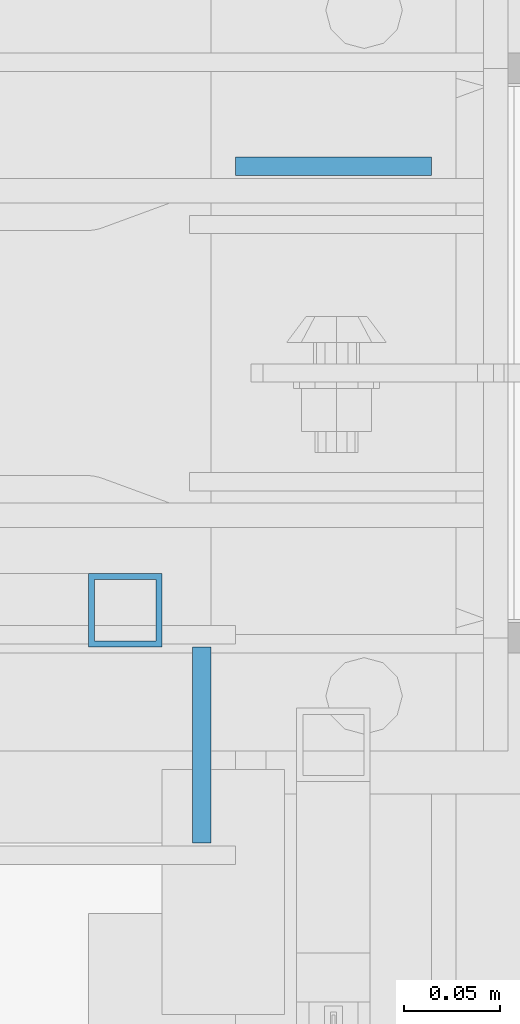
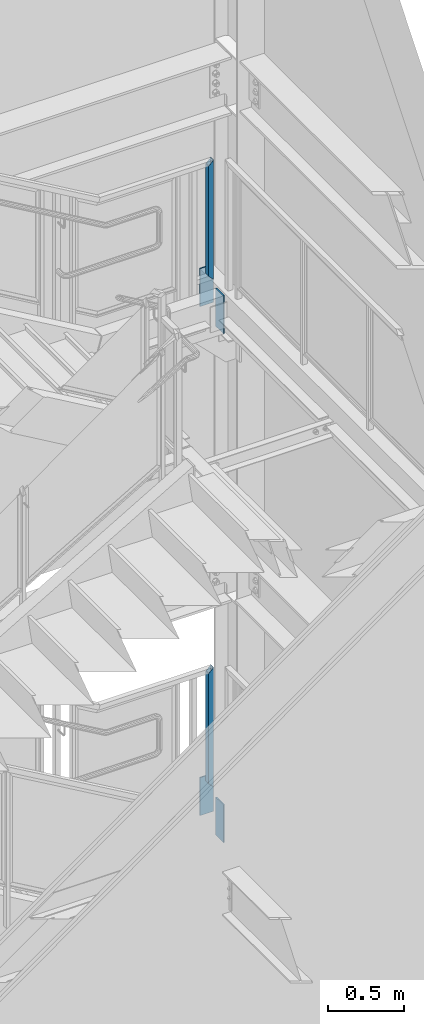
# One storey, part 600 of 1179: 6 columns, 6 elements without a shape of their own.
"""IFC2X3 building model written with IfcOpenShell, lengths in millimetres."""

from ifc_helpers import new_model, si_unit, frame, origin_with_axes, place, context, subcontext, project, spatial, faceted_brep, material, type_object, element, aggregate, save


model = new_model("IFC2X3")

# Units and contexts
model_context = context("Model", 3, precision=1e-05, world=origin_with_axes())
body_context = subcontext(model_context, "Body", "Model", "MODEL_VIEW")
ifc_project = project(units=[si_unit("LENGTHUNIT", "METRE", prefix="MILLI"), si_unit("AREAUNIT", "SQUARE_METRE"), si_unit("VOLUMEUNIT", "CUBIC_METRE"), si_unit("MASSUNIT", "GRAM", prefix="KILO"), si_unit("TIMEUNIT", "SECOND"), si_unit("PLANEANGLEUNIT", "RADIAN"), si_unit("SOLIDANGLEUNIT", "STERADIAN"), si_unit("THERMODYNAMICTEMPERATUREUNIT", "DEGREE_CELSIUS"), si_unit("LUMINOUSINTENSITYUNIT", "LUMEN")], contexts=[model_context])

# Site, building, storey
site_placement = place(None, origin_with_axes())
site = spatial("IfcSite", under=ifc_project, at=site_placement, CompositionType="ELEMENT")
building_placement = place(site_placement, origin_with_axes())
building = spatial("IfcBuilding", under=site, at=building_placement, Name="Undefined", CompositionType="ELEMENT")
storey_placement = place(building_placement, origin_with_axes())
storey = spatial("IfcBuildingStorey", under=building, at=storey_placement, Name="Undefined", CompositionType="ELEMENT", Elevation=0.0)

# Assembly, column
assembly_1_placement = place(storey_placement, origin_with_axes())
assembly_1 = element("IfcElementAssembly", 1, at=assembly_1_placement, inside=storey, Name="GUARDRAIL", AssemblyPlace="NOTDEFINED", PredefinedType="RIGID_FRAME")
ifc_material_1 = material()
column_type_1 = type_object("IfcColumnType", Name="HSS1-1/2X1-1/2X1/8", PredefinedType="NOTDEFINED")
column_1_placement = place(assembly_1_placement, frame((24006.175, 41065.449999241, 6337.29999924757), z_axis=(0.0, -1.0, 0.0), x_axis=(0.0, 0.0, 1.0)))
column_1 = element("IfcColumn", 2, at=column_1_placement, type_object=column_type_1, material=ifc_material_1, Name="POST", ObjectType="HSS1-1/2X1-1/2X1/8", context=body_context, shape_type="Brep", body=[
    faceted_brep([(15.874999282998, 15.874999282998, -15.8749992829999), (-15.8749985180002, -15.8749992829999, -15.874999282998), (936.624999224079, -15.8749992830017, -15.874999282998), (904.875000658081, 15.8749992830017, -15.874999282998), (-15.8749992830017, -15.874999282998, 15.8749992829999), (936.624999224079, -15.8749992830017, 15.874999282998), (15.8750000479995, 15.8749992829999, 15.874999282998), (904.875000658081, 15.8749992830017, 15.874999282998), (19.0499999999993, 19.0499992349996, -19.0499992350015), (19.0499999999993, 19.0499992349996, 19.0499992350015), (901.700000706081, 19.0499992350015, 19.0499992350015), (901.700000706081, 19.0499992350015, -19.0499992350015), (-19.0499992350015, -19.0499992350015, 19.0499992349996), (939.799999176079, -19.0499992350015, 19.0499992350015), (-19.04999847, -19.0499992349996, -19.0499992350015), (939.799999176079, -19.0499992350015, -19.0499992350015)], [[[0, 1, 2, 3]], [[1, 4, 5, 2]], [[4, 6, 7, 5]], [[6, 0, 3, 7]], [[8, 9, 10, 11]], [[9, 12, 13, 10]], [[12, 14, 15, 13]], [[14, 8, 11, 15]], [[13, 15, 11, 10], [5, 7, 3, 2]], [[14, 12, 9, 8], [6, 4, 1, 0]]]),
])
aggregate(assembly_1, [column_1])

assembly_2_placement = place(storey_placement, origin_with_axes())
assembly_2 = element("IfcElementAssembly", 3, at=assembly_2_placement, inside=storey, Name="GUARDRAIL", AssemblyPlace="NOTDEFINED", PredefinedType="RIGID_FRAME")
column_2_placement = place(assembly_2_placement, frame((24006.1750006124, 41065.449999241, 2263.77499922779), z_axis=(-1.0, 0.0, 0.0), x_axis=(0.0, 0.0, 1.0)))
column_2 = element("IfcColumn", 4, at=column_2_placement, type_object=column_type_1, material=ifc_material_1, Name="POST", ObjectType="HSS1-1/2X1-1/2X1/8", context=body_context, shape_type="Brep", body=[
    faceted_brep([(-15.8749992829989, 15.874999282998, -15.8749992830017), (-15.8749985180002, -15.8749992829999, -15.874999282998), (936.624999224079, -15.8749992830017, -15.874999282998), (936.624999231291, 15.874999282998, -15.8749992830017), (15.8749992830003, -15.874999282998, 15.8749992830017), (904.875000665292, -15.874999282998, 15.8749992830017), (15.8750000479995, 15.8749992829999, 15.874999282998), (904.875000658081, 15.8749992830017, 15.874999282998), (-19.0499992349987, 19.0499992350015, -19.0499992350015), (19.0499999999993, 19.0499992349996, 19.0499992350015), (901.700000706081, 19.0499992350015, 19.0499992350015), (939.799999183291, 19.0499992350015, -19.0499992350015), (19.0499999999993, -19.0499992349996, 19.0500001223481), (901.700000713292, -19.0499992350015, 19.0499992350015), (-19.04999847, -19.0499992349996, -19.0499992350015), (939.799999176079, -19.0499992350015, -19.0499992350015)], [[[0, 1, 2, 3]], [[1, 4, 5, 2]], [[4, 6, 7, 5]], [[6, 0, 3, 7]], [[8, 9, 10, 11]], [[9, 12, 13, 10]], [[12, 14, 15, 13]], [[14, 8, 11, 15]], [[13, 15, 11, 10], [5, 7, 3, 2]], [[14, 12, 9, 8], [6, 4, 1, 0]]]),
])
aggregate(assembly_2, [column_2])

assembly_3_placement = place(storey_placement, origin_with_axes())
assembly_3 = element("IfcElementAssembly", 5, at=assembly_3_placement, inside=storey, Name="STAIR", AssemblyPlace="NOTDEFINED", PredefinedType="RIGID_FRAME")
ifc_material_2 = material(Name="STEEL/A36")
column_type_2 = type_object("IfcColumnType", PredefinedType="NOTDEFINED")
column_3_placement = place(assembly_3_placement, frame((24045.8625, 40995.6, 5937.25000001257), z_axis=(0.0, 1.0, 0.0), x_axis=(0.0, 0.0, 1.0)))
column_3 = element("IfcColumn", 6, at=column_3_placement, type_object=column_type_2, material=ifc_material_2, Name="PLATE", context=body_context, shape_type="Brep", body=[
    faceted_brep([(0.0, 4.76249999999982, -50.7999999999993), (0.0, 4.76249999999982, 50.7999999999993), (304.799999999999, 4.76249999999709, 50.8), (304.799999999999, 4.76249999999709, -50.8), (0.0, -4.76249999999982, 50.7999999999993), (304.799999999999, -4.76249999999709, 50.8), (0.0, -4.76249999999982, -50.7999999999993), (304.799999999999, -4.76249999999709, -50.8)], [[[0, 1, 2, 3]], [[1, 4, 5, 2]], [[4, 6, 7, 5]], [[6, 0, 3, 7]], [[5, 7, 3, 2]], [[6, 4, 1, 0]]]),
])
aggregate(assembly_3, [column_3])

assembly_4_placement = place(storey_placement, origin_with_axes())
assembly_4 = element("IfcElementAssembly", 7, at=assembly_4_placement, inside=storey, Name="BEAM", AssemblyPlace="NOTDEFINED", PredefinedType="RIGID_FRAME")
column_4_placement = place(assembly_4_placement, frame((24114.125, 41295.6375, 5937.25), z_axis=(-1.0, 0.0, 0.0), x_axis=(0.0, 0.0, 1.0)))
column_4 = element("IfcColumn", 8, at=column_4_placement, type_object=column_type_2, material=ifc_material_2, Name="PLATE", context=body_context, shape_type="Brep", body=[
    faceted_brep([(0.0, 4.76249999999982, -50.7999999999993), (0.0, 4.76249999999982, 50.7999999999993), (304.799999999999, 4.76249999999709, 50.8), (304.799999999999, 4.76249999999709, -50.8), (0.0, -4.76249999999982, 50.7999999999993), (304.799999999999, -4.76249999999709, 50.8), (0.0, -4.76249999999982, -50.7999999999993), (304.799999999999, -4.76249999999709, -50.8)], [[[0, 1, 2, 3]], [[1, 4, 5, 2]], [[4, 6, 7, 5]], [[6, 0, 3, 7]], [[5, 7, 3, 2]], [[6, 4, 1, 0]]]),
])
aggregate(assembly_4, [column_4])

assembly_5_placement = place(storey_placement, origin_with_axes())
assembly_5 = element("IfcElementAssembly", 9, at=assembly_5_placement, inside=storey, Name="BEAM", AssemblyPlace="NOTDEFINED", PredefinedType="RIGID_FRAME")
column_5_placement = place(assembly_5_placement, frame((24114.1250004143, 41295.6375, 1851.025), z_axis=(-1.0, 0.0, 0.0), x_axis=(0.0, 0.0, 1.0)))
column_5 = element("IfcColumn", 10, at=column_5_placement, type_object=column_type_2, material=ifc_material_2, Name="PLATE", context=body_context, shape_type="Brep", body=[
    faceted_brep([(0.0, 4.76249999999982, -50.7999999999993), (0.0, 4.76249999999982, 50.7999999999993), (304.799999999999, 4.76249999999709, 50.8), (304.799999999999, 4.76249999999709, -50.8), (0.0, -4.76249999999982, 50.7999999999993), (304.799999999999, -4.76249999999709, 50.8), (0.0, -4.76249999999982, -50.7999999999993), (304.799999999999, -4.76249999999709, -50.8)], [[[0, 1, 2, 3]], [[1, 4, 5, 2]], [[4, 6, 7, 5]], [[6, 0, 3, 7]], [[5, 7, 3, 2]], [[6, 4, 1, 0]]]),
])
aggregate(assembly_5, [column_5])

assembly_6_placement = place(storey_placement, origin_with_axes())
assembly_6 = element("IfcElementAssembly", 11, at=assembly_6_placement, inside=storey, Name="STAIR", AssemblyPlace="NOTDEFINED", PredefinedType="RIGID_FRAME")
column_6_placement = place(assembly_6_placement, frame((24045.8625004143, 40995.5999999994, 1851.025), z_axis=(0.0, 1.0, 0.0), x_axis=(0.0, 0.0, 1.0)))
column_6 = element("IfcColumn", 12, at=column_6_placement, type_object=column_type_2, material=ifc_material_2, Name="PLATE", context=body_context, shape_type="Brep", body=[
    faceted_brep([(0.0, 4.76249999999982, -50.7999999999993), (0.0, 4.76249999999982, 50.7999999999993), (304.799999999999, 4.76249999999709, 50.8), (304.799999999999, 4.76249999999709, -50.8), (0.0, -4.76249999999982, 50.7999999999993), (304.799999999999, -4.76249999999709, 50.8), (0.0, -4.76249999999982, -50.7999999999993), (304.799999999999, -4.76249999999709, -50.8)], [[[0, 1, 2, 3]], [[1, 4, 5, 2]], [[4, 6, 7, 5]], [[6, 0, 3, 7]], [[5, 7, 3, 2]], [[6, 4, 1, 0]]]),
])
aggregate(assembly_6, [column_6])

save(model, "model.ifc")
